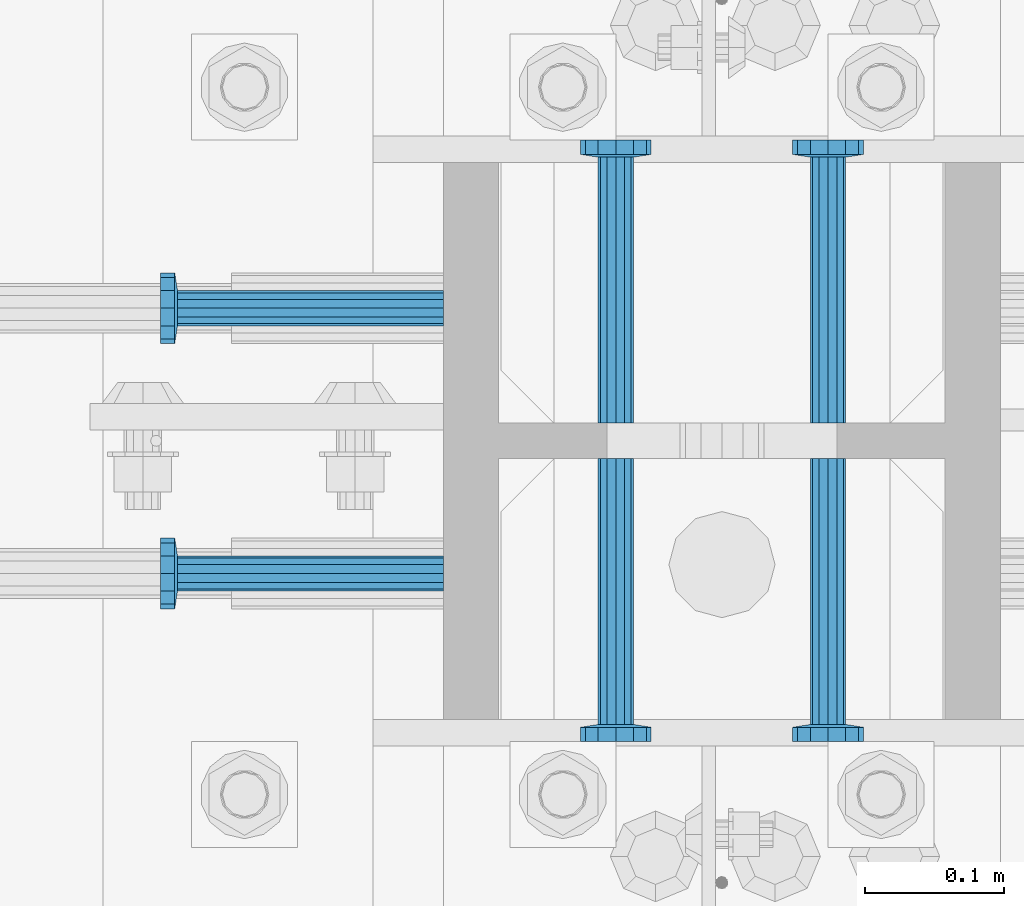
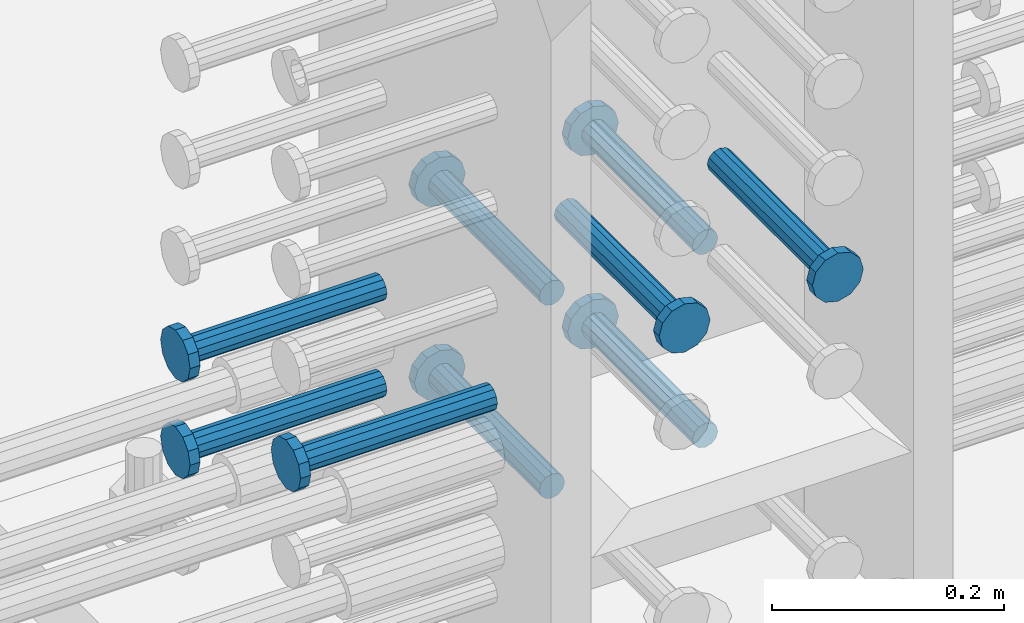
# One storey, part 1193 of 1763: 9 beams, 1 element without a shape of its own.
"""IFC2X3 building model written with IfcOpenShell, lengths in millimetres."""

from ifc_helpers import new_model, si_unit, frame, origin_with_axes, place, context, subcontext, project, spatial, faceted_brep, material, type_object, element, aggregate, save


model = new_model("IFC2X3")

# Units and contexts
model_context = context("Model", 3, precision=1e-05, world=origin_with_axes())
body_context = subcontext(model_context, "Body", "Model", "MODEL_VIEW")
ifc_project = project(units=[si_unit("LENGTHUNIT", "METRE", prefix="MILLI"), si_unit("AREAUNIT", "SQUARE_METRE"), si_unit("VOLUMEUNIT", "CUBIC_METRE"), si_unit("MASSUNIT", "GRAM", prefix="KILO"), si_unit("TIMEUNIT", "SECOND"), si_unit("PLANEANGLEUNIT", "RADIAN"), si_unit("SOLIDANGLEUNIT", "STERADIAN"), si_unit("THERMODYNAMICTEMPERATUREUNIT", "DEGREE_CELSIUS"), si_unit("LUMINOUSINTENSITYUNIT", "LUMEN")], contexts=[model_context])

# Site, building, storey
site_placement = place(None, origin_with_axes())
site = spatial("IfcSite", under=ifc_project, at=site_placement, CompositionType="ELEMENT")
building_placement = place(site_placement, origin_with_axes())
building = spatial("IfcBuilding", under=site, at=building_placement, Name="Undefined", CompositionType="ELEMENT")
storey_placement = place(building_placement, origin_with_axes())
storey = spatial("IfcBuildingStorey", under=building, at=storey_placement, Name="Undefined", CompositionType="ELEMENT", Elevation=0.0)

# Assembly, beams
assembly_placement = place(storey_placement, origin_with_axes())
assembly = element("IfcElementAssembly", 1, at=assembly_placement, inside=storey, Name="COLUMN", AssemblyPlace="NOTDEFINED", PredefinedType="RIGID_FRAME")
ifc_material = material(Name="STEEL/A108")
beam_type = type_object("IfcBeamType", PredefinedType="NOTDEFINED")
beam_1_placement = place(assembly_placement, frame((-72567.2373420903, 444.499999886566, 4318.00000000004), z_axis=(1.0, 0.0, 0.0), x_axis=(0.0, -1.0, 0.0)))
beam_1 = element("IfcBeam", 2, at=beam_1_placement, type_object=beam_type, material=ifc_material, Name="HEADED STUD ANCHOR", context=body_context, shape_type="Brep", body=[
    faceted_brep([(0.0, -12.6999999999971, -1.81898940354586e-12), (3.63797880709171e-12, -11.0, -6.34999990463257), (191.00799999576, -11.0, -6.34999990454889), (191.007999995752, -12.6999998092651, 8.36735125631094e-11), (7.27595761418343e-12, -6.34999990463257, -11.0), (191.00799999576, -6.34999990463257, -10.9999999999163), (3.63797880709171e-12, 0.0, -12.6999998092651), (191.00799999576, 0.0, -12.6999998091815), (7.27595761418343e-12, 6.34999990463257, -11.0), (191.00799999576, 6.34999990463257, -10.9999999999163), (3.63797880709171e-12, 11.0, -6.34999990463257), (191.00799999576, 11.0, -6.34999990454889), (0.0, 12.6999999999971, -1.81898940354586e-12), (191.007999995752, 12.6999998092651, 8.36735125631094e-11), (0.0, 11.0, 6.34999990463257), (191.007999995752, 11.0, 6.34999990471624), (-3.63797880709171e-12, 6.34999990463257, 11.0), (191.007999995749, 6.34999990463257, 11.0000000000837), (-3.63797880709171e-12, 0.0, 12.6999998092651), (191.007999995749, 0.0, 12.6999998093488), (-3.63797880709171e-12, -6.34999990463257, 11.0), (191.007999995749, -6.34999990463257, 11.0000000000837), (0.0, -11.0, 6.34999990463257), (191.007999995752, -11.0, 6.34999990471624), (193.039999995715, -22.0, -12.6999998091796), (193.039999995708, -25.3999996185303, 8.54925019666553e-11), (193.039999995719, -12.6999998092651, -21.9999999999145), (193.039999995719, 0.0, -25.3999996184448), (193.039999995719, 12.6999998092651, -21.9999999999145), (193.039999995715, 22.0, -12.6999998091796), (193.039999995708, 25.3999996185303, 8.54925019666553e-11), (193.039999995704, 22.0, 12.6999998093506), (193.039999995701, 12.6999998092651, 22.0000000000855), (193.039999995697, 0.0, 25.3999996186158), (193.039999995701, -12.6999998092651, 22.0000000000855), (193.039999995704, -22.0, 12.6999998093506), (203.199999995486, -22.0, -12.6999998091742), (203.199999995482, -25.3999996185303, 9.09494701772928e-11), (203.199999995493, -12.6999998092651, -21.9999999999091), (203.199999995493, 0.0, -25.3999996184393), (203.199999995493, 12.6999998092651, -21.9999999999091), (203.199999995486, 22.0, -12.6999998091742), (203.199999995482, 25.3999996185303, 9.09494701772928e-11), (203.199999995479, 22.0, 12.6999998093561), (203.199999995475, 12.6999998092651, 22.0000000000909), (203.199999995471, 0.0, 25.3999996186212), (203.199999995475, -12.6999998092651, 22.0000000000909), (203.199999995479, -22.0, 12.6999998093561)], [[[0, 1, 2, 3]], [[1, 4, 5, 2]], [[4, 6, 7, 5]], [[6, 8, 9, 7]], [[8, 10, 11, 9]], [[10, 12, 13, 11]], [[12, 14, 15, 13]], [[14, 16, 17, 15]], [[16, 18, 19, 17]], [[18, 20, 21, 19]], [[20, 22, 23, 21]], [[22, 0, 3, 23]], [[22, 20, 18, 16, 14, 12, 10, 8, 6, 4, 1, 0]], [[3, 2, 24, 25]], [[2, 5, 26, 24]], [[5, 7, 27, 26]], [[7, 9, 28, 27]], [[9, 11, 29, 28]], [[11, 13, 30, 29]], [[13, 15, 31, 30]], [[15, 17, 32, 31]], [[17, 19, 33, 32]], [[19, 21, 34, 33]], [[21, 23, 35, 34]], [[23, 3, 25, 35]], [[25, 24, 36, 37]], [[24, 26, 38, 36]], [[26, 27, 39, 38]], [[27, 28, 40, 39]], [[28, 29, 41, 40]], [[29, 30, 42, 41]], [[30, 31, 43, 42]], [[31, 32, 44, 43]], [[32, 33, 45, 44]], [[33, 34, 46, 45]], [[34, 35, 47, 46]], [[35, 25, 37, 47]], [[38, 39, 40, 41, 42, 43, 44, 45, 46, 47, 37, 36]]]),
])
beam_2_placement = place(assembly_placement, frame((-72414.8373420912, 444.500000000843, 4318.00000000004), z_axis=(1.0, 0.0, 0.0), x_axis=(0.0, -1.0, 0.0)))
beam_2 = element("IfcBeam", 3, at=beam_2_placement, type_object=beam_type, material=ifc_material, Name="HEADED STUD ANCHOR", context=body_context, shape_type="Brep", body=[
    faceted_brep([(0.0, -12.6999999999971, -1.81898940354586e-12), (3.63797880709171e-12, -11.0, -6.34999990463257), (191.00799999576, -11.0, -6.34999990454889), (191.007999995752, -12.6999998092651, 8.36735125631094e-11), (7.27595761418343e-12, -6.34999990463257, -11.0), (191.00799999576, -6.34999990463257, -10.9999999999163), (3.63797880709171e-12, 0.0, -12.6999998092651), (191.00799999576, 0.0, -12.6999998091815), (7.27595761418343e-12, 6.34999990463257, -11.0), (191.00799999576, 6.34999990463257, -10.9999999999163), (3.63797880709171e-12, 11.0, -6.34999990463257), (191.00799999576, 11.0, -6.34999990454889), (0.0, 12.6999999999971, -1.81898940354586e-12), (191.007999995752, 12.6999998092651, 8.36735125631094e-11), (0.0, 11.0, 6.34999990463257), (191.007999995752, 11.0, 6.34999990471624), (-3.63797880709171e-12, 6.34999990463257, 11.0), (191.007999995749, 6.34999990463257, 11.0000000000837), (-3.63797880709171e-12, 0.0, 12.6999998092651), (191.007999995749, 0.0, 12.6999998093488), (-3.63797880709171e-12, -6.34999990463257, 11.0), (191.007999995749, -6.34999990463257, 11.0000000000837), (0.0, -11.0, 6.34999990463257), (191.007999995752, -11.0, 6.34999990471624), (193.039999995715, -22.0, -12.6999998091796), (193.039999995708, -25.3999996185303, 8.54925019666553e-11), (193.039999995719, -12.6999998092651, -21.9999999999145), (193.039999995719, 0.0, -25.3999996184448), (193.039999995719, 12.6999998092651, -21.9999999999145), (193.039999995715, 22.0, -12.6999998091796), (193.039999995708, 25.3999996185303, 8.54925019666553e-11), (193.039999995704, 22.0, 12.6999998093506), (193.039999995701, 12.6999998092651, 22.0000000000855), (193.039999995697, 0.0, 25.3999996186158), (193.039999995701, -12.6999998092651, 22.0000000000855), (193.039999995704, -22.0, 12.6999998093506), (203.199999995486, -22.0, -12.6999998091742), (203.199999995482, -25.3999996185303, 9.09494701772928e-11), (203.199999995493, -12.6999998092651, -21.9999999999091), (203.199999995493, 0.0, -25.3999996184393), (203.199999995493, 12.6999998092651, -21.9999999999091), (203.199999995486, 22.0, -12.6999998091742), (203.199999995482, 25.3999996185303, 9.09494701772928e-11), (203.199999995479, 22.0, 12.6999998093561), (203.199999995475, 12.6999998092651, 22.0000000000909), (203.199999995471, 0.0, 25.3999996186212), (203.199999995475, -12.6999998092651, 22.0000000000909), (203.199999995479, -22.0, 12.6999998093561)], [[[0, 1, 2, 3]], [[1, 4, 5, 2]], [[4, 6, 7, 5]], [[6, 8, 9, 7]], [[8, 10, 11, 9]], [[10, 12, 13, 11]], [[12, 14, 15, 13]], [[14, 16, 17, 15]], [[16, 18, 19, 17]], [[18, 20, 21, 19]], [[20, 22, 23, 21]], [[22, 0, 3, 23]], [[22, 20, 18, 16, 14, 12, 10, 8, 6, 4, 1, 0]], [[3, 2, 24, 25]], [[2, 5, 26, 24]], [[5, 7, 27, 26]], [[7, 9, 28, 27]], [[9, 11, 29, 28]], [[11, 13, 30, 29]], [[13, 15, 31, 30]], [[15, 17, 32, 31]], [[17, 19, 33, 32]], [[19, 21, 34, 33]], [[21, 23, 35, 34]], [[23, 3, 25, 35]], [[25, 24, 36, 37]], [[24, 26, 38, 36]], [[26, 27, 39, 38]], [[27, 28, 40, 39]], [[28, 29, 41, 40]], [[29, 30, 42, 41]], [[30, 31, 43, 42]], [[31, 32, 44, 43]], [[32, 33, 45, 44]], [[33, 34, 46, 45]], [[34, 35, 47, 46]], [[35, 25, 37, 47]], [[38, 39, 40, 41, 42, 43, 44, 45, 46, 47, 37, 36]]]),
])
beam_3_placement = place(assembly_placement, frame((-72414.837343099, 469.900000000843, 4216.40000000002), z_axis=(1.0, 0.0, 0.0), x_axis=(0.0, 1.0, 0.0)))
beam_3 = element("IfcBeam", 4, at=beam_3_placement, type_object=beam_type, material=ifc_material, Name="HEADED STUD ANCHOR", context=body_context, shape_type="Brep", body=[
    faceted_brep([(0.0, -12.6999999999971, -1.81898940354586e-12), (3.63797880709171e-12, -11.0, -6.34999990463257), (191.00799999576, -11.0, -6.34999990454889), (191.007999995752, -12.6999998092651, 8.36735125631094e-11), (7.27595761418343e-12, -6.34999990463257, -11.0), (191.00799999576, -6.34999990463257, -10.9999999999163), (3.63797880709171e-12, 0.0, -12.6999998092651), (191.00799999576, 0.0, -12.6999998091815), (7.27595761418343e-12, 6.34999990463257, -11.0), (191.00799999576, 6.34999990463257, -10.9999999999163), (3.63797880709171e-12, 11.0, -6.34999990463257), (191.00799999576, 11.0, -6.34999990454889), (0.0, 12.6999999999971, -1.81898940354586e-12), (191.007999995752, 12.6999998092651, 8.36735125631094e-11), (0.0, 11.0, 6.34999990463257), (191.007999995752, 11.0, 6.34999990471624), (-3.63797880709171e-12, 6.34999990463257, 11.0), (191.007999995749, 6.34999990463257, 11.0000000000837), (-3.63797880709171e-12, 0.0, 12.6999998092651), (191.007999995749, 0.0, 12.6999998093488), (-3.63797880709171e-12, -6.34999990463257, 11.0), (191.007999995749, -6.34999990463257, 11.0000000000837), (0.0, -11.0, 6.34999990463257), (191.007999995752, -11.0, 6.34999990471624), (193.039999995715, -22.0, -12.6999998091796), (193.039999995708, -25.3999996185303, 8.54925019666553e-11), (193.039999995719, -12.6999998092651, -21.9999999999145), (193.039999995719, 0.0, -25.3999996184448), (193.039999995719, 12.6999998092651, -21.9999999999145), (193.039999995715, 22.0, -12.6999998091796), (193.039999995708, 25.3999996185303, 8.54925019666553e-11), (193.039999995704, 22.0, 12.6999998093506), (193.039999995701, 12.6999998092651, 22.0000000000855), (193.039999995697, 0.0, 25.3999996186158), (193.039999995701, -12.6999998092651, 22.0000000000855), (193.039999995704, -22.0, 12.6999998093506), (203.199999995486, -22.0, -12.6999998091742), (203.199999995482, -25.3999996185303, 9.09494701772928e-11), (203.199999995493, -12.6999998092651, -21.9999999999091), (203.199999995493, 0.0, -25.3999996184393), (203.199999995493, 12.6999998092651, -21.9999999999091), (203.199999995486, 22.0, -12.6999998091742), (203.199999995482, 25.3999996185303, 9.09494701772928e-11), (203.199999995479, 22.0, 12.6999998093561), (203.199999995475, 12.6999998092651, 22.0000000000909), (203.199999995471, 0.0, 25.3999996186212), (203.199999995475, -12.6999998092651, 22.0000000000909), (203.199999995479, -22.0, 12.6999998093561)], [[[0, 1, 2, 3]], [[1, 4, 5, 2]], [[4, 6, 7, 5]], [[6, 8, 9, 7]], [[8, 10, 11, 9]], [[10, 12, 13, 11]], [[12, 14, 15, 13]], [[14, 16, 17, 15]], [[16, 18, 19, 17]], [[18, 20, 21, 19]], [[20, 22, 23, 21]], [[22, 0, 3, 23]], [[22, 20, 18, 16, 14, 12, 10, 8, 6, 4, 1, 0]], [[3, 2, 24, 25]], [[2, 5, 26, 24]], [[5, 7, 27, 26]], [[7, 9, 28, 27]], [[9, 11, 29, 28]], [[11, 13, 30, 29]], [[13, 15, 31, 30]], [[15, 17, 32, 31]], [[17, 19, 33, 32]], [[19, 21, 34, 33]], [[21, 23, 35, 34]], [[23, 3, 25, 35]], [[25, 24, 36, 37]], [[24, 26, 38, 36]], [[26, 27, 39, 38]], [[27, 28, 40, 39]], [[28, 29, 41, 40]], [[29, 30, 42, 41]], [[30, 31, 43, 42]], [[31, 32, 44, 43]], [[32, 33, 45, 44]], [[33, 34, 46, 45]], [[34, 35, 47, 46]], [[35, 25, 37, 47]], [[38, 39, 40, 41, 42, 43, 44, 45, 46, 47, 37, 36]]]),
])
beam_4_placement = place(assembly_placement, frame((-72567.2373430988, 469.899999003702, 4216.40000000002), z_axis=(1.0, 0.0, 0.0), x_axis=(0.0, 1.0, 0.0)))
beam_4 = element("IfcBeam", 5, at=beam_4_placement, type_object=beam_type, material=ifc_material, Name="HEADED STUD ANCHOR", context=body_context, shape_type="Brep", body=[
    faceted_brep([(0.0, -12.6999999999971, -1.81898940354586e-12), (3.63797880709171e-12, -11.0, -6.34999990463257), (191.00799999576, -11.0, -6.34999990454889), (191.007999995752, -12.6999998092651, 8.36735125631094e-11), (7.27595761418343e-12, -6.34999990463257, -11.0), (191.00799999576, -6.34999990463257, -10.9999999999163), (3.63797880709171e-12, 0.0, -12.6999998092651), (191.00799999576, 0.0, -12.6999998091815), (7.27595761418343e-12, 6.34999990463257, -11.0), (191.00799999576, 6.34999990463257, -10.9999999999163), (3.63797880709171e-12, 11.0, -6.34999990463257), (191.00799999576, 11.0, -6.34999990454889), (0.0, 12.6999999999971, -1.81898940354586e-12), (191.007999995752, 12.6999998092651, 8.36735125631094e-11), (0.0, 11.0, 6.34999990463257), (191.007999995752, 11.0, 6.34999990471624), (-3.63797880709171e-12, 6.34999990463257, 11.0), (191.007999995749, 6.34999990463257, 11.0000000000837), (-3.63797880709171e-12, 0.0, 12.6999998092651), (191.007999995749, 0.0, 12.6999998093488), (-3.63797880709171e-12, -6.34999990463257, 11.0), (191.007999995749, -6.34999990463257, 11.0000000000837), (0.0, -11.0, 6.34999990463257), (191.007999995752, -11.0, 6.34999990471624), (193.039999995715, -22.0, -12.6999998091796), (193.039999995708, -25.3999996185303, 8.54925019666553e-11), (193.039999995719, -12.6999998092651, -21.9999999999145), (193.039999995719, 0.0, -25.3999996184448), (193.039999995719, 12.6999998092651, -21.9999999999145), (193.039999995715, 22.0, -12.6999998091796), (193.039999995708, 25.3999996185303, 8.54925019666553e-11), (193.039999995704, 22.0, 12.6999998093506), (193.039999995701, 12.6999998092651, 22.0000000000855), (193.039999995697, 0.0, 25.3999996186158), (193.039999995701, -12.6999998092651, 22.0000000000855), (193.039999995704, -22.0, 12.6999998093506), (203.199999995486, -22.0, -12.6999998091742), (203.199999995482, -25.3999996185303, 9.09494701772928e-11), (203.199999995493, -12.6999998092651, -21.9999999999091), (203.199999995493, 0.0, -25.3999996184393), (203.199999995493, 12.6999998092651, -21.9999999999091), (203.199999995486, 22.0, -12.6999998091742), (203.199999995482, 25.3999996185303, 9.09494701772928e-11), (203.199999995479, 22.0, 12.6999998093561), (203.199999995475, 12.6999998092651, 22.0000000000909), (203.199999995471, 0.0, 25.3999996186212), (203.199999995475, -12.6999998092651, 22.0000000000909), (203.199999995479, -22.0, 12.6999998093561)], [[[0, 1, 2, 3]], [[1, 4, 5, 2]], [[4, 6, 7, 5]], [[6, 8, 9, 7]], [[8, 10, 11, 9]], [[10, 12, 13, 11]], [[12, 14, 15, 13]], [[14, 16, 17, 15]], [[16, 18, 19, 17]], [[18, 20, 21, 19]], [[20, 22, 23, 21]], [[22, 0, 3, 23]], [[22, 20, 18, 16, 14, 12, 10, 8, 6, 4, 1, 0]], [[3, 2, 24, 25]], [[2, 5, 26, 24]], [[5, 7, 27, 26]], [[7, 9, 28, 27]], [[9, 11, 29, 28]], [[11, 13, 30, 29]], [[13, 15, 31, 30]], [[15, 17, 32, 31]], [[17, 19, 33, 32]], [[19, 21, 34, 33]], [[21, 23, 35, 34]], [[23, 3, 25, 35]], [[25, 24, 36, 37]], [[24, 26, 38, 36]], [[26, 27, 39, 38]], [[27, 28, 40, 39]], [[28, 29, 41, 40]], [[29, 30, 42, 41]], [[30, 31, 43, 42]], [[31, 32, 44, 43]], [[32, 33, 45, 44]], [[33, 34, 46, 45]], [[34, 35, 47, 46]], [[35, 25, 37, 47]], [[38, 39, 40, 41, 42, 43, 44, 45, 46, 47, 37, 36]]]),
])
beam_5_placement = place(assembly_placement, frame((-72567.2372743638, 469.899999003702, 4013.2), z_axis=(1.0, 0.0, 0.0), x_axis=(0.0, 1.0, 0.0)))
beam_5 = element("IfcBeam", 6, at=beam_5_placement, type_object=beam_type, material=ifc_material, Name="HEADED STUD ANCHOR", context=body_context, shape_type="Brep", body=[
    faceted_brep([(0.0, -12.6999999999971, -1.81898940354586e-12), (3.63797880709171e-12, -11.0, -6.34999990463257), (191.00799999576, -11.0, -6.34999990454889), (191.007999995752, -12.6999998092651, 8.36735125631094e-11), (7.27595761418343e-12, -6.34999990463257, -11.0), (191.00799999576, -6.34999990463257, -10.9999999999163), (3.63797880709171e-12, 0.0, -12.6999998092651), (191.00799999576, 0.0, -12.6999998091815), (7.27595761418343e-12, 6.34999990463257, -11.0), (191.00799999576, 6.34999990463257, -10.9999999999163), (3.63797880709171e-12, 11.0, -6.34999990463257), (191.00799999576, 11.0, -6.34999990454889), (0.0, 12.6999999999971, -1.81898940354586e-12), (191.007999995752, 12.6999998092651, 8.36735125631094e-11), (0.0, 11.0, 6.34999990463257), (191.007999995752, 11.0, 6.34999990471624), (-3.63797880709171e-12, 6.34999990463257, 11.0), (191.007999995749, 6.34999990463257, 11.0000000000837), (-3.63797880709171e-12, 0.0, 12.6999998092651), (191.007999995749, 0.0, 12.6999998093488), (-3.63797880709171e-12, -6.34999990463257, 11.0), (191.007999995749, -6.34999990463257, 11.0000000000837), (0.0, -11.0, 6.34999990463257), (191.007999995752, -11.0, 6.34999990471624), (193.039999995715, -22.0, -12.6999998091796), (193.039999995708, -25.3999996185303, 8.54925019666553e-11), (193.039999995719, -12.6999998092651, -21.9999999999145), (193.039999995719, 0.0, -25.3999996184448), (193.039999995719, 12.6999998092651, -21.9999999999145), (193.039999995715, 22.0, -12.6999998091796), (193.039999995708, 25.3999996185303, 8.54925019666553e-11), (193.039999995704, 22.0, 12.6999998093506), (193.039999995701, 12.6999998092651, 22.0000000000855), (193.039999995697, 0.0, 25.3999996186158), (193.039999995701, -12.6999998092651, 22.0000000000855), (193.039999995704, -22.0, 12.6999998093506), (203.199999995486, -22.0, -12.6999998091742), (203.199999995482, -25.3999996185303, 9.09494701772928e-11), (203.199999995493, -12.6999998092651, -21.9999999999091), (203.199999995493, 0.0, -25.3999996184393), (203.199999995493, 12.6999998092651, -21.9999999999091), (203.199999995486, 22.0, -12.6999998091742), (203.199999995482, 25.3999996185303, 9.09494701772928e-11), (203.199999995479, 22.0, 12.6999998093561), (203.199999995475, 12.6999998092651, 22.0000000000909), (203.199999995471, 0.0, 25.3999996186212), (203.199999995475, -12.6999998092651, 22.0000000000909), (203.199999995479, -22.0, 12.6999998093561)], [[[0, 1, 2, 3]], [[1, 4, 5, 2]], [[4, 6, 7, 5]], [[6, 8, 9, 7]], [[8, 10, 11, 9]], [[10, 12, 13, 11]], [[12, 14, 15, 13]], [[14, 16, 17, 15]], [[16, 18, 19, 17]], [[18, 20, 21, 19]], [[20, 22, 23, 21]], [[22, 0, 3, 23]], [[22, 20, 18, 16, 14, 12, 10, 8, 6, 4, 1, 0]], [[3, 2, 24, 25]], [[2, 5, 26, 24]], [[5, 7, 27, 26]], [[7, 9, 28, 27]], [[9, 11, 29, 28]], [[11, 13, 30, 29]], [[13, 15, 31, 30]], [[15, 17, 32, 31]], [[17, 19, 33, 32]], [[19, 21, 34, 33]], [[21, 23, 35, 34]], [[23, 3, 25, 35]], [[25, 24, 36, 37]], [[24, 26, 38, 36]], [[26, 27, 39, 38]], [[27, 28, 40, 39]], [[28, 29, 41, 40]], [[29, 30, 42, 41]], [[30, 31, 43, 42]], [[31, 32, 44, 43]], [[32, 33, 45, 44]], [[33, 34, 46, 45]], [[34, 35, 47, 46]], [[35, 25, 37, 47]], [[38, 39, 40, 41, 42, 43, 44, 45, 46, 47, 37, 36]]]),
])
beam_6_placement = place(assembly_placement, frame((-72414.837274364, 469.900000000843, 4013.2), z_axis=(1.0, 0.0, 0.0), x_axis=(0.0, 1.0, 0.0)))
beam_6 = element("IfcBeam", 7, at=beam_6_placement, type_object=beam_type, material=ifc_material, Name="HEADED STUD ANCHOR", context=body_context, shape_type="Brep", body=[
    faceted_brep([(0.0, -12.6999999999971, -1.81898940354586e-12), (3.63797880709171e-12, -11.0, -6.34999990463257), (191.00799999576, -11.0, -6.34999990454889), (191.007999995752, -12.6999998092651, 8.36735125631094e-11), (7.27595761418343e-12, -6.34999990463257, -11.0), (191.00799999576, -6.34999990463257, -10.9999999999163), (3.63797880709171e-12, 0.0, -12.6999998092651), (191.00799999576, 0.0, -12.6999998091815), (7.27595761418343e-12, 6.34999990463257, -11.0), (191.00799999576, 6.34999990463257, -10.9999999999163), (3.63797880709171e-12, 11.0, -6.34999990463257), (191.00799999576, 11.0, -6.34999990454889), (0.0, 12.6999999999971, -1.81898940354586e-12), (191.007999995752, 12.6999998092651, 8.36735125631094e-11), (0.0, 11.0, 6.34999990463257), (191.007999995752, 11.0, 6.34999990471624), (-3.63797880709171e-12, 6.34999990463257, 11.0), (191.007999995749, 6.34999990463257, 11.0000000000837), (-3.63797880709171e-12, 0.0, 12.6999998092651), (191.007999995749, 0.0, 12.6999998093488), (-3.63797880709171e-12, -6.34999990463257, 11.0), (191.007999995749, -6.34999990463257, 11.0000000000837), (0.0, -11.0, 6.34999990463257), (191.007999995752, -11.0, 6.34999990471624), (193.039999995715, -22.0, -12.6999998091796), (193.039999995708, -25.3999996185303, 8.54925019666553e-11), (193.039999995719, -12.6999998092651, -21.9999999999145), (193.039999995719, 0.0, -25.3999996184448), (193.039999995719, 12.6999998092651, -21.9999999999145), (193.039999995715, 22.0, -12.6999998091796), (193.039999995708, 25.3999996185303, 8.54925019666553e-11), (193.039999995704, 22.0, 12.6999998093506), (193.039999995701, 12.6999998092651, 22.0000000000855), (193.039999995697, 0.0, 25.3999996186158), (193.039999995701, -12.6999998092651, 22.0000000000855), (193.039999995704, -22.0, 12.6999998093506), (203.199999995486, -22.0, -12.6999998091742), (203.199999995482, -25.3999996185303, 9.09494701772928e-11), (203.199999995493, -12.6999998092651, -21.9999999999091), (203.199999995493, 0.0, -25.3999996184393), (203.199999995493, 12.6999998092651, -21.9999999999091), (203.199999995486, 22.0, -12.6999998091742), (203.199999995482, 25.3999996185303, 9.09494701772928e-11), (203.199999995479, 22.0, 12.6999998093561), (203.199999995475, 12.6999998092651, 22.0000000000909), (203.199999995471, 0.0, 25.3999996186212), (203.199999995475, -12.6999998092651, 22.0000000000909), (203.199999995479, -22.0, 12.6999998093561)], [[[0, 1, 2, 3]], [[1, 4, 5, 2]], [[4, 6, 7, 5]], [[6, 8, 9, 7]], [[8, 10, 11, 9]], [[10, 12, 13, 11]], [[12, 14, 15, 13]], [[14, 16, 17, 15]], [[16, 18, 19, 17]], [[18, 20, 21, 19]], [[20, 22, 23, 21]], [[22, 0, 3, 23]], [[22, 20, 18, 16, 14, 12, 10, 8, 6, 4, 1, 0]], [[3, 2, 24, 25]], [[2, 5, 26, 24]], [[5, 7, 27, 26]], [[7, 9, 28, 27]], [[9, 11, 29, 28]], [[11, 13, 30, 29]], [[13, 15, 31, 30]], [[15, 17, 32, 31]], [[17, 19, 33, 32]], [[19, 21, 34, 33]], [[21, 23, 35, 34]], [[23, 3, 25, 35]], [[25, 24, 36, 37]], [[24, 26, 38, 36]], [[26, 27, 39, 38]], [[27, 28, 40, 39]], [[28, 29, 41, 40]], [[29, 30, 42, 41]], [[30, 31, 43, 42]], [[31, 32, 44, 43]], [[32, 33, 45, 44]], [[33, 34, 46, 45]], [[34, 35, 47, 46]], [[35, 25, 37, 47]], [[38, 39, 40, 41, 42, 43, 44, 45, 46, 47, 37, 36]]]),
])
beam_7_placement = place(assembly_placement, frame((-72691.0622049617, 552.45000000066, 4216.40000000002), z_axis=(0.0, 1.0, 0.0), x_axis=(-1.0, 0.0, 0.0)))
beam_7 = element("IfcBeam", 8, at=beam_7_placement, type_object=beam_type, material=ifc_material, Name="HEADED STUD ANCHOR", context=body_context, shape_type="Brep", body=[
    faceted_brep([(0.0, -12.6999999999971, -1.81898940354586e-12), (3.63797880709171e-12, -11.0, -6.34999990463257), (191.00799999576, -11.0, -6.34999990454889), (191.007999995752, -12.6999998092651, 8.36735125631094e-11), (7.27595761418343e-12, -6.34999990463257, -11.0), (191.00799999576, -6.34999990463257, -10.9999999999163), (3.63797880709171e-12, 0.0, -12.6999998092651), (191.00799999576, 0.0, -12.6999998091815), (7.27595761418343e-12, 6.34999990463257, -11.0), (191.00799999576, 6.34999990463257, -10.9999999999163), (3.63797880709171e-12, 11.0, -6.34999990463257), (191.00799999576, 11.0, -6.34999990454889), (0.0, 12.6999999999971, -1.81898940354586e-12), (191.007999995752, 12.6999998092651, 8.36735125631094e-11), (0.0, 11.0, 6.34999990463257), (191.007999995752, 11.0, 6.34999990471624), (-3.63797880709171e-12, 6.34999990463257, 11.0), (191.007999995749, 6.34999990463257, 11.0000000000837), (-3.63797880709171e-12, 0.0, 12.6999998092651), (191.007999995749, 0.0, 12.6999998093488), (-3.63797880709171e-12, -6.34999990463257, 11.0), (191.007999995749, -6.34999990463257, 11.0000000000837), (0.0, -11.0, 6.34999990463257), (191.007999995752, -11.0, 6.34999990471624), (193.039999995715, -22.0, -12.6999998091796), (193.039999995708, -25.3999996185303, 8.54925019666553e-11), (193.039999995719, -12.6999998092651, -21.9999999999145), (193.039999995719, 0.0, -25.3999996184448), (193.039999995719, 12.6999998092651, -21.9999999999145), (193.039999995715, 22.0, -12.6999998091796), (193.039999995708, 25.3999996185303, 8.54925019666553e-11), (193.039999995704, 22.0, 12.6999998093506), (193.039999995701, 12.6999998092651, 22.0000000000855), (193.039999995697, 0.0, 25.3999996186158), (193.039999995701, -12.6999998092651, 22.0000000000855), (193.039999995704, -22.0, 12.6999998093506), (203.199999995486, -22.0, -12.6999998091742), (203.199999995482, -25.3999996185303, 9.09494701772928e-11), (203.199999995493, -12.6999998092651, -21.9999999999091), (203.199999995493, 0.0, -25.3999996184393), (203.199999995493, 12.6999998092651, -21.9999999999091), (203.199999995486, 22.0, -12.6999998091742), (203.199999995482, 25.3999996185303, 9.09494701772928e-11), (203.199999995479, 22.0, 12.6999998093561), (203.199999995475, 12.6999998092651, 22.0000000000909), (203.199999995471, 0.0, 25.3999996186212), (203.199999995475, -12.6999998092651, 22.0000000000909), (203.199999995479, -22.0, 12.6999998093561)], [[[0, 1, 2, 3]], [[1, 4, 5, 2]], [[4, 6, 7, 5]], [[6, 8, 9, 7]], [[8, 10, 11, 9]], [[10, 12, 13, 11]], [[12, 14, 15, 13]], [[14, 16, 17, 15]], [[16, 18, 19, 17]], [[18, 20, 21, 19]], [[20, 22, 23, 21]], [[22, 0, 3, 23]], [[22, 20, 18, 16, 14, 12, 10, 8, 6, 4, 1, 0]], [[3, 2, 24, 25]], [[2, 5, 26, 24]], [[5, 7, 27, 26]], [[7, 9, 28, 27]], [[9, 11, 29, 28]], [[11, 13, 30, 29]], [[13, 15, 31, 30]], [[15, 17, 32, 31]], [[17, 19, 33, 32]], [[19, 21, 34, 33]], [[21, 23, 35, 34]], [[23, 3, 25, 35]], [[25, 24, 36, 37]], [[24, 26, 38, 36]], [[26, 27, 39, 38]], [[27, 28, 40, 39]], [[28, 29, 41, 40]], [[29, 30, 42, 41]], [[30, 31, 43, 42]], [[31, 32, 44, 43]], [[32, 33, 45, 44]], [[33, 34, 46, 45]], [[34, 35, 47, 46]], [[35, 25, 37, 47]], [[38, 39, 40, 41, 42, 43, 44, 45, 46, 47, 37, 36]]]),
])
beam_8_placement = place(assembly_placement, frame((-72691.0622049617, 552.45000000066, 4114.80000000002), z_axis=(0.0, 1.0, 0.0), x_axis=(-1.0, 0.0, 0.0)))
beam_8 = element("IfcBeam", 9, at=beam_8_placement, type_object=beam_type, material=ifc_material, Name="HEADED STUD ANCHOR", context=body_context, shape_type="Brep", body=[
    faceted_brep([(0.0, -12.6999999999971, -1.81898940354586e-12), (3.63797880709171e-12, -11.0, -6.34999990463257), (191.00799999576, -11.0, -6.34999990454889), (191.007999995752, -12.6999998092651, 8.36735125631094e-11), (7.27595761418343e-12, -6.34999990463257, -11.0), (191.00799999576, -6.34999990463257, -10.9999999999163), (3.63797880709171e-12, 0.0, -12.6999998092651), (191.00799999576, 0.0, -12.6999998091815), (7.27595761418343e-12, 6.34999990463257, -11.0), (191.00799999576, 6.34999990463257, -10.9999999999163), (3.63797880709171e-12, 11.0, -6.34999990463257), (191.00799999576, 11.0, -6.34999990454889), (0.0, 12.6999999999971, -1.81898940354586e-12), (191.007999995752, 12.6999998092651, 8.36735125631094e-11), (0.0, 11.0, 6.34999990463257), (191.007999995752, 11.0, 6.34999990471624), (-3.63797880709171e-12, 6.34999990463257, 11.0), (191.007999995749, 6.34999990463257, 11.0000000000837), (-3.63797880709171e-12, 0.0, 12.6999998092651), (191.007999995749, 0.0, 12.6999998093488), (-3.63797880709171e-12, -6.34999990463257, 11.0), (191.007999995749, -6.34999990463257, 11.0000000000837), (0.0, -11.0, 6.34999990463257), (191.007999995752, -11.0, 6.34999990471624), (193.039999995715, -22.0, -12.6999998091796), (193.039999995708, -25.3999996185303, 8.54925019666553e-11), (193.039999995719, -12.6999998092651, -21.9999999999145), (193.039999995719, 0.0, -25.3999996184448), (193.039999995719, 12.6999998092651, -21.9999999999145), (193.039999995715, 22.0, -12.6999998091796), (193.039999995708, 25.3999996185303, 8.54925019666553e-11), (193.039999995704, 22.0, 12.6999998093506), (193.039999995701, 12.6999998092651, 22.0000000000855), (193.039999995697, 0.0, 25.3999996186158), (193.039999995701, -12.6999998092651, 22.0000000000855), (193.039999995704, -22.0, 12.6999998093506), (203.199999995486, -22.0, -12.6999998091742), (203.199999995482, -25.3999996185303, 9.09494701772928e-11), (203.199999995493, -12.6999998092651, -21.9999999999091), (203.199999995493, 0.0, -25.3999996184393), (203.199999995493, 12.6999998092651, -21.9999999999091), (203.199999995486, 22.0, -12.6999998091742), (203.199999995482, 25.3999996185303, 9.09494701772928e-11), (203.199999995479, 22.0, 12.6999998093561), (203.199999995475, 12.6999998092651, 22.0000000000909), (203.199999995471, 0.0, 25.3999996186212), (203.199999995475, -12.6999998092651, 22.0000000000909), (203.199999995479, -22.0, 12.6999998093561)], [[[0, 1, 2, 3]], [[1, 4, 5, 2]], [[4, 6, 7, 5]], [[6, 8, 9, 7]], [[8, 10, 11, 9]], [[10, 12, 13, 11]], [[12, 14, 15, 13]], [[14, 16, 17, 15]], [[16, 18, 19, 17]], [[18, 20, 21, 19]], [[20, 22, 23, 21]], [[22, 0, 3, 23]], [[22, 20, 18, 16, 14, 12, 10, 8, 6, 4, 1, 0]], [[3, 2, 24, 25]], [[2, 5, 26, 24]], [[5, 7, 27, 26]], [[7, 9, 28, 27]], [[9, 11, 29, 28]], [[11, 13, 30, 29]], [[13, 15, 31, 30]], [[15, 17, 32, 31]], [[17, 19, 33, 32]], [[19, 21, 34, 33]], [[21, 23, 35, 34]], [[23, 3, 25, 35]], [[25, 24, 36, 37]], [[24, 26, 38, 36]], [[26, 27, 39, 38]], [[27, 28, 40, 39]], [[28, 29, 41, 40]], [[29, 30, 42, 41]], [[30, 31, 43, 42]], [[31, 32, 44, 43]], [[32, 33, 45, 44]], [[33, 34, 46, 45]], [[34, 35, 47, 46]], [[35, 25, 37, 47]], [[38, 39, 40, 41, 42, 43, 44, 45, 46, 47, 37, 36]]]),
])
beam_9_placement = place(assembly_placement, frame((-72691.0622736973, 361.950000000834, 4216.40000000002), z_axis=(0.0, 1.0, 0.0), x_axis=(-1.0, 0.0, 0.0)))
beam_9 = element("IfcBeam", 10, at=beam_9_placement, type_object=beam_type, material=ifc_material, Name="HEADED STUD ANCHOR", context=body_context, shape_type="Brep", body=[
    faceted_brep([(0.0, -12.6999999999971, -1.81898940354586e-12), (3.63797880709171e-12, -11.0, -6.34999990463257), (191.00799999576, -11.0, -6.34999990454889), (191.007999995752, -12.6999998092651, 8.36735125631094e-11), (7.27595761418343e-12, -6.34999990463257, -11.0), (191.00799999576, -6.34999990463257, -10.9999999999163), (3.63797880709171e-12, 0.0, -12.6999998092651), (191.00799999576, 0.0, -12.6999998091815), (7.27595761418343e-12, 6.34999990463257, -11.0), (191.00799999576, 6.34999990463257, -10.9999999999163), (3.63797880709171e-12, 11.0, -6.34999990463257), (191.00799999576, 11.0, -6.34999990454889), (0.0, 12.6999999999971, -1.81898940354586e-12), (191.007999995752, 12.6999998092651, 8.36735125631094e-11), (0.0, 11.0, 6.34999990463257), (191.007999995752, 11.0, 6.34999990471624), (-3.63797880709171e-12, 6.34999990463257, 11.0), (191.007999995749, 6.34999990463257, 11.0000000000837), (-3.63797880709171e-12, 0.0, 12.6999998092651), (191.007999995749, 0.0, 12.6999998093488), (-3.63797880709171e-12, -6.34999990463257, 11.0), (191.007999995749, -6.34999990463257, 11.0000000000837), (0.0, -11.0, 6.34999990463257), (191.007999995752, -11.0, 6.34999990471624), (193.039999995715, -22.0, -12.6999998091796), (193.039999995708, -25.3999996185303, 8.54925019666553e-11), (193.039999995719, -12.6999998092651, -21.9999999999145), (193.039999995719, 0.0, -25.3999996184448), (193.039999995719, 12.6999998092651, -21.9999999999145), (193.039999995715, 22.0, -12.6999998091796), (193.039999995708, 25.3999996185303, 8.54925019666553e-11), (193.039999995704, 22.0, 12.6999998093506), (193.039999995701, 12.6999998092651, 22.0000000000855), (193.039999995697, 0.0, 25.3999996186158), (193.039999995701, -12.6999998092651, 22.0000000000855), (193.039999995704, -22.0, 12.6999998093506), (203.199999995486, -22.0, -12.6999998091742), (203.199999995482, -25.3999996185303, 9.09494701772928e-11), (203.199999995493, -12.6999998092651, -21.9999999999091), (203.199999995493, 0.0, -25.3999996184393), (203.199999995493, 12.6999998092651, -21.9999999999091), (203.199999995486, 22.0, -12.6999998091742), (203.199999995482, 25.3999996185303, 9.09494701772928e-11), (203.199999995479, 22.0, 12.6999998093561), (203.199999995475, 12.6999998092651, 22.0000000000909), (203.199999995471, 0.0, 25.3999996186212), (203.199999995475, -12.6999998092651, 22.0000000000909), (203.199999995479, -22.0, 12.6999998093561)], [[[0, 1, 2, 3]], [[1, 4, 5, 2]], [[4, 6, 7, 5]], [[6, 8, 9, 7]], [[8, 10, 11, 9]], [[10, 12, 13, 11]], [[12, 14, 15, 13]], [[14, 16, 17, 15]], [[16, 18, 19, 17]], [[18, 20, 21, 19]], [[20, 22, 23, 21]], [[22, 0, 3, 23]], [[22, 20, 18, 16, 14, 12, 10, 8, 6, 4, 1, 0]], [[3, 2, 24, 25]], [[2, 5, 26, 24]], [[5, 7, 27, 26]], [[7, 9, 28, 27]], [[9, 11, 29, 28]], [[11, 13, 30, 29]], [[13, 15, 31, 30]], [[15, 17, 32, 31]], [[17, 19, 33, 32]], [[19, 21, 34, 33]], [[21, 23, 35, 34]], [[23, 3, 25, 35]], [[25, 24, 36, 37]], [[24, 26, 38, 36]], [[26, 27, 39, 38]], [[27, 28, 40, 39]], [[28, 29, 41, 40]], [[29, 30, 42, 41]], [[30, 31, 43, 42]], [[31, 32, 44, 43]], [[32, 33, 45, 44]], [[33, 34, 46, 45]], [[34, 35, 47, 46]], [[35, 25, 37, 47]], [[38, 39, 40, 41, 42, 43, 44, 45, 46, 47, 37, 36]]]),
])
aggregate(assembly, [beam_1, beam_2, beam_3, beam_4, beam_5, beam_6, beam_7, beam_8, beam_9])

save(model, "model.ifc")
